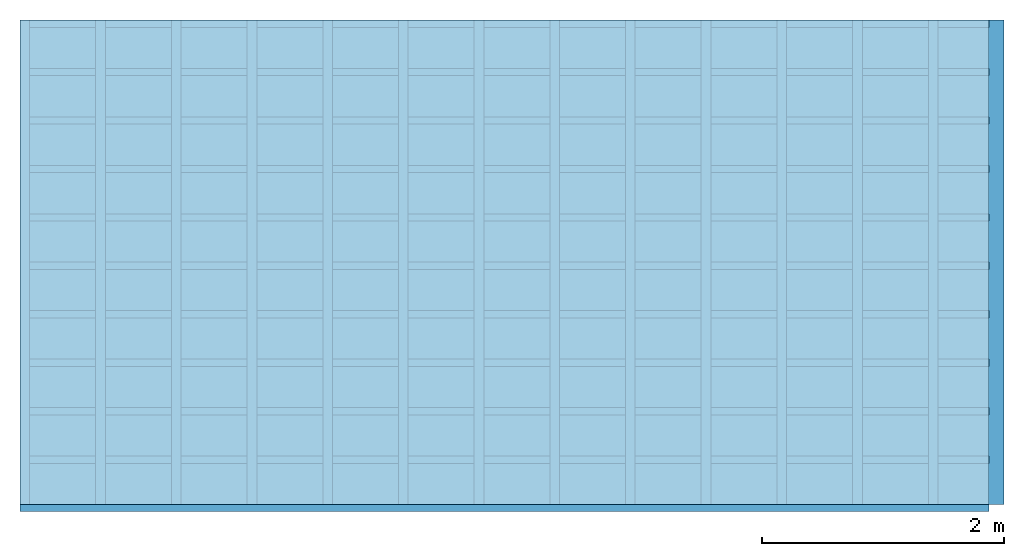
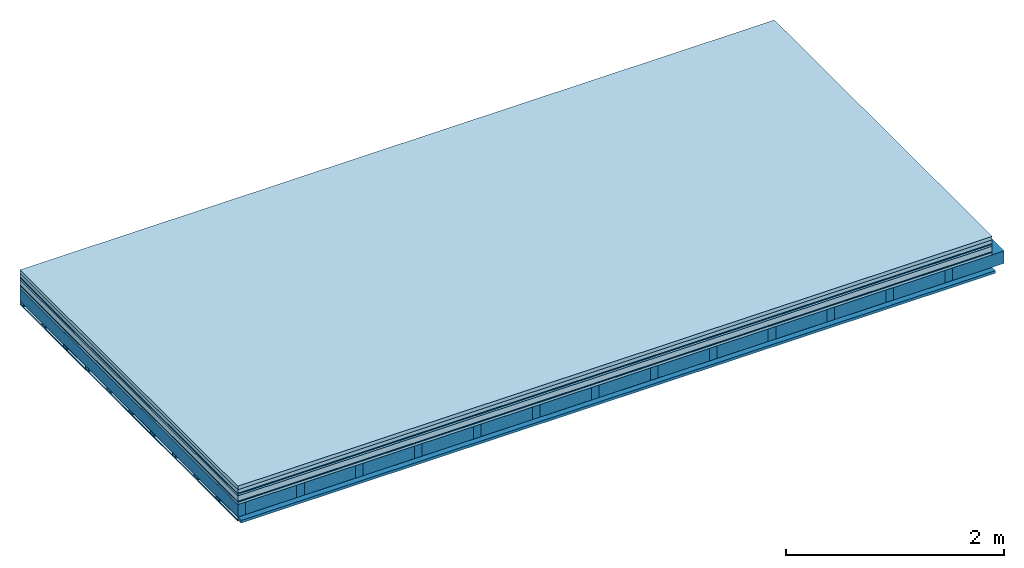
# One storey: 10 plates, 3 members, 1 element without a shape of its own.
"""IFC4 building model written with IfcOpenShell, lengths in metres."""

from ifc_helpers import new_model, si_unit, derived_unit, direction, frame, frame_2d, origin, origin_with_axes, place, context, project, spatial, rectangle, extrude, material, layer, layer_set, type_object, element, aggregate, save


model = new_model("IFC4")

# Units and contexts
plan_context = context("Plan", 3, precision=1e-05, world=origin(), true_north=direction((0.0, 1.0)))
model_context = context("Model", 3, precision=1e-05, world=origin(), true_north=direction((0.0, 1.0)))
ifc_project = project(units=[si_unit("LENGTHUNIT", "METRE"), derived_unit("SOUNDPRESSUREUNIT", [(si_unit("PRESSUREUNIT", "PASCAL", prefix="MICRO"), 0)]), si_unit("ENERGYUNIT", "JOULE", prefix="MEGA"), si_unit("MASSUNIT", "GRAM", prefix="KILO"), derived_unit("THERMALTRANSMITTANCEUNIT", [(si_unit("POWERUNIT", "WATT"), 1), (si_unit("AREAUNIT", "SQUARE_METRE"), -1), (si_unit("THERMODYNAMICTEMPERATUREUNIT", "KELVIN"), -1)]), derived_unit("AREADENSITYUNIT", [(si_unit("MASSUNIT", "GRAM", prefix="KILO"), 1), (si_unit("AREAUNIT", "SQUARE_METRE"), -1)]), derived_unit("USERDEFINED", [(si_unit("ENERGYUNIT", "JOULE", prefix="MEGA"), 1), (si_unit("AREAUNIT", "SQUARE_METRE"), -1)])], contexts=[plan_context, model_context])

# Site, building, storey
site = spatial("IfcSite", under=ifc_project)
building_placement = place(None, origin())
building = spatial("IfcBuilding", under=site, at=building_placement)
storey_placement = place(building_placement, origin())
storey = spatial("IfcBuildingStorey", under=building, at=storey_placement)

# Slab, members, plates
ifc_material_1 = material(Name="Garden plates", Category="02.007")
ifc_layer_1 = layer(ifc_material_1, 0.04, Name="Use and protection layer 3")
ifc_material_2 = material(Name="Gravel 8-16mm", Category="03.011")
ifc_layer_2 = layer(ifc_material_2, 0.04, Name="Use and protection layer 2")
ifc_material_3 = material(Name="Protective layer", Category="09.007")
ifc_layer_3 = layer(ifc_material_3, 0.01, Name="Use and protection layer 1")
ifc_material_4 = material(Name="Bituminous", Category="09.003")
ifc_layer_4 = layer(ifc_material_4, 0.02, Name="Seal")
ifc_material_5 = material(Name="Mineral wool", Category="10.008")
ifc_layer_5 = layer(ifc_material_5, 0.06, Name="Exterior insulation layer 1")
ifc_material_6 = material(Name="Vapor-permeable barrier", Category="09.006")
ifc_layer_6 = layer(ifc_material_6, 0.01, Name="layer / temporary roof")
ifc_material_7 = material(Name="3-layer panels", Category="07.001")
ifc_layer_7 = layer(ifc_material_7, 0.027, Name="above 2nd layer")
ifc_material_8 = material(Name="no composite action")
ifc_layer_8 = layer(ifc_material_8, 0.0, Name="Bond")
ifc_layer_9 = layer(None, 0.14, Name="Support")
ifc_material_9 = material(Name="of the art")
ifc_layer_10 = layer(ifc_material_9, 0.0, Name="Bond")
ifc_material_10 = material(Name="Vapor barrier polyethylene (PE)", Category="09.002")
ifc_layer_11 = layer(ifc_material_10, 0.001, Name="Vapor barrier")
ifc_layer_12 = layer(None, 0.03, Name="Battens / profiles")
ifc_material_11 = material(Name="Plasterboard type A", Category="03.008")
ifc_layer_13 = layer(ifc_material_11, 0.0125, Name="Covering below 1st layer")
ifc_material_12 = material(Category="04.001")
ifc_layer_14 = layer(ifc_material_12, 0.003, Name="Surface below")
ifc_layer_set = layer_set([ifc_layer_1, ifc_layer_2, ifc_layer_3, ifc_layer_4, ifc_layer_5, ifc_layer_6, ifc_layer_7, ifc_layer_8, ifc_layer_9, ifc_layer_10, ifc_layer_11, ifc_layer_12, ifc_layer_13, ifc_layer_14])
slab_type = type_object("IfcSlabType", Name="F0111", PredefinedType="NOTDEFINED", material=ifc_layer_set)
slab_placement = place(None, frame((0.0, 0.0, 0.0), z_axis=(0.0, 0.0, -1.0), x_axis=(1.0, 0.0, 0.0)))
slab = element("IfcSlab", 1, at=slab_placement, inside=storey, type_object=slab_type, material=ifc_layer_set, Name="Slab #1")
ifc_material_13 = material()
member_1_placement = place(slab_placement, origin())
member_1 = element("IfcMember", 2, at=member_1_placement, material=ifc_material_13, Name="Support", context=plan_context, shape_type="SweptSolid", body=[
    extrude(rectangle(XDim=0.08, YDim=0.14, at=frame_2d((0.04, 0.07), x_axis=(1.0, 0.0))), frame((0.0, 4.0, 0.207), z_axis=(0.0, -1.0, 0.0), x_axis=(1.0, 0.0, 0.0)), (0.0, 0.0, 1.0), 4.0),
    extrude(rectangle(XDim=0.08, YDim=0.14, at=frame_2d((0.04, 0.07), x_axis=(1.0, 0.0))), frame((0.625, 4.0, 0.207), z_axis=(0.0, -1.0, 0.0), x_axis=(1.0, 0.0, 0.0)), (0.0, 0.0, 1.0), 4.0),
    extrude(rectangle(XDim=0.08, YDim=0.14, at=frame_2d((0.04, 0.07), x_axis=(1.0, 0.0))), frame((1.25, 4.0, 0.207), z_axis=(0.0, -1.0, 0.0), x_axis=(1.0, 0.0, 0.0)), (0.0, 0.0, 1.0), 4.0),
    extrude(rectangle(XDim=0.08, YDim=0.14, at=frame_2d((0.04, 0.07), x_axis=(1.0, 0.0))), frame((1.875, 4.0, 0.207), z_axis=(0.0, -1.0, 0.0), x_axis=(1.0, 0.0, 0.0)), (0.0, 0.0, 1.0), 4.0),
    extrude(rectangle(XDim=0.08, YDim=0.14, at=frame_2d((0.04, 0.07), x_axis=(1.0, 0.0))), frame((2.5, 4.0, 0.207), z_axis=(0.0, -1.0, 0.0), x_axis=(1.0, 0.0, 0.0)), (0.0, 0.0, 1.0), 4.0),
    extrude(rectangle(XDim=0.08, YDim=0.14, at=frame_2d((0.04, 0.07), x_axis=(1.0, 0.0))), frame((3.125, 4.0, 0.207), z_axis=(0.0, -1.0, 0.0), x_axis=(1.0, 0.0, 0.0)), (0.0, 0.0, 1.0), 4.0),
    extrude(rectangle(XDim=0.08, YDim=0.14, at=frame_2d((0.04, 0.07), x_axis=(1.0, 0.0))), frame((3.75, 4.0, 0.207), z_axis=(0.0, -1.0, 0.0), x_axis=(1.0, 0.0, 0.0)), (0.0, 0.0, 1.0), 4.0),
    extrude(rectangle(XDim=0.08, YDim=0.14, at=frame_2d((0.04, 0.07), x_axis=(1.0, 0.0))), frame((4.375, 4.0, 0.207), z_axis=(0.0, -1.0, 0.0), x_axis=(1.0, 0.0, 0.0)), (0.0, 0.0, 1.0), 4.0),
    extrude(rectangle(XDim=0.08, YDim=0.14, at=frame_2d((0.04, 0.07), x_axis=(1.0, 0.0))), frame((5.0, 4.0, 0.207), z_axis=(0.0, -1.0, 0.0), x_axis=(1.0, 0.0, 0.0)), (0.0, 0.0, 1.0), 4.0),
    extrude(rectangle(XDim=0.08, YDim=0.14, at=frame_2d((0.04, 0.07), x_axis=(1.0, 0.0))), frame((5.625, 4.0, 0.207), z_axis=(0.0, -1.0, 0.0), x_axis=(1.0, 0.0, 0.0)), (0.0, 0.0, 1.0), 4.0),
    extrude(rectangle(XDim=0.08, YDim=0.14, at=frame_2d((0.04, 0.07), x_axis=(1.0, 0.0))), frame((6.25, 4.0, 0.207), z_axis=(0.0, -1.0, 0.0), x_axis=(1.0, 0.0, 0.0)), (0.0, 0.0, 1.0), 4.0),
    extrude(rectangle(XDim=0.08, YDim=0.14, at=frame_2d((0.04, 0.07), x_axis=(1.0, 0.0))), frame((6.875, 4.0, 0.207), z_axis=(0.0, -1.0, 0.0), x_axis=(1.0, 0.0, 0.0)), (0.0, 0.0, 1.0), 4.0),
    extrude(rectangle(XDim=0.08, YDim=0.14, at=frame_2d((0.04, 0.07), x_axis=(1.0, 0.0))), frame((7.5, 4.0, 0.207), z_axis=(0.0, -1.0, 0.0), x_axis=(1.0, 0.0, 0.0)), (0.0, 0.0, 1.0), 4.0),
])
ifc_material_14 = material()
member_2_placement = place(slab_placement, origin())
member_2 = element("IfcMember", 3, at=member_2_placement, material=ifc_material_14, Name="Cavity", context=plan_context, shape_type="SweptSolid", body=[
    extrude(rectangle(XDim=0.545, YDim=0.14, at=frame_2d((0.2725, 0.07), x_axis=(1.0, 0.0))), frame((0.08, 4.0, 0.207), z_axis=(0.0, -1.0, 0.0), x_axis=(1.0, 0.0, 0.0)), (0.0, 0.0, 1.0), 4.0),
    extrude(rectangle(XDim=0.545, YDim=0.14, at=frame_2d((0.2725, 0.07), x_axis=(1.0, 0.0))), frame((0.705, 4.0, 0.207), z_axis=(0.0, -1.0, 0.0), x_axis=(1.0, 0.0, 0.0)), (0.0, 0.0, 1.0), 4.0),
    extrude(rectangle(XDim=0.545, YDim=0.14, at=frame_2d((0.2725, 0.07), x_axis=(1.0, 0.0))), frame((1.33, 4.0, 0.207), z_axis=(0.0, -1.0, 0.0), x_axis=(1.0, 0.0, 0.0)), (0.0, 0.0, 1.0), 4.0),
    extrude(rectangle(XDim=0.545, YDim=0.14, at=frame_2d((0.2725, 0.07), x_axis=(1.0, 0.0))), frame((1.955, 4.0, 0.207), z_axis=(0.0, -1.0, 0.0), x_axis=(1.0, 0.0, 0.0)), (0.0, 0.0, 1.0), 4.0),
    extrude(rectangle(XDim=0.545, YDim=0.14, at=frame_2d((0.2725, 0.07), x_axis=(1.0, 0.0))), frame((2.58, 4.0, 0.207), z_axis=(0.0, -1.0, 0.0), x_axis=(1.0, 0.0, 0.0)), (0.0, 0.0, 1.0), 4.0),
    extrude(rectangle(XDim=0.545, YDim=0.14, at=frame_2d((0.2725, 0.07), x_axis=(1.0, 0.0))), frame((3.205, 4.0, 0.207), z_axis=(0.0, -1.0, 0.0), x_axis=(1.0, 0.0, 0.0)), (0.0, 0.0, 1.0), 4.0),
    extrude(rectangle(XDim=0.545, YDim=0.14, at=frame_2d((0.2725, 0.07), x_axis=(1.0, 0.0))), frame((3.83, 4.0, 0.207), z_axis=(0.0, -1.0, 0.0), x_axis=(1.0, 0.0, 0.0)), (0.0, 0.0, 1.0), 4.0),
    extrude(rectangle(XDim=0.545, YDim=0.14, at=frame_2d((0.2725, 0.07), x_axis=(1.0, 0.0))), frame((4.455, 4.0, 0.207), z_axis=(0.0, -1.0, 0.0), x_axis=(1.0, 0.0, 0.0)), (0.0, 0.0, 1.0), 4.0),
    extrude(rectangle(XDim=0.545, YDim=0.14, at=frame_2d((0.2725, 0.07), x_axis=(1.0, 0.0))), frame((5.08, 4.0, 0.207), z_axis=(0.0, -1.0, 0.0), x_axis=(1.0, 0.0, 0.0)), (0.0, 0.0, 1.0), 4.0),
    extrude(rectangle(XDim=0.545, YDim=0.14, at=frame_2d((0.2725, 0.07), x_axis=(1.0, 0.0))), frame((5.705, 4.0, 0.207), z_axis=(0.0, -1.0, 0.0), x_axis=(1.0, 0.0, 0.0)), (0.0, 0.0, 1.0), 4.0),
    extrude(rectangle(XDim=0.545, YDim=0.14, at=frame_2d((0.2725, 0.07), x_axis=(1.0, 0.0))), frame((6.33, 4.0, 0.207), z_axis=(0.0, -1.0, 0.0), x_axis=(1.0, 0.0, 0.0)), (0.0, 0.0, 1.0), 4.0),
    extrude(rectangle(XDim=0.545, YDim=0.14, at=frame_2d((0.2725, 0.07), x_axis=(1.0, 0.0))), frame((6.955, 4.0, 0.207), z_axis=(0.0, -1.0, 0.0), x_axis=(1.0, 0.0, 0.0)), (0.0, 0.0, 1.0), 4.0),
    extrude(rectangle(XDim=0.545, YDim=0.14, at=frame_2d((0.2725, 0.07), x_axis=(1.0, 0.0))), frame((7.58, 4.0, 0.207), z_axis=(0.0, -1.0, 0.0), x_axis=(1.0, 0.0, 0.0)), (0.0, 0.0, 1.0), 4.0),
])
ifc_material_15 = material()
member_3_placement = place(slab_placement, origin())
member_3 = element("IfcMember", 4, at=member_3_placement, material=ifc_material_15, Name="Battens / profiles", context=plan_context, shape_type="SweptSolid", body=[
    extrude(rectangle(XDim=0.06, YDim=0.03, at=frame_2d((0.03, 0.015), x_axis=(1.0, 0.0))), frame((0.0, 0.0, 0.348), z_axis=(1.0, 0.0, 0.0), x_axis=(0.0, 1.0, 0.0)), (0.0, 0.0, 1.0), 8.0),
    extrude(rectangle(XDim=0.06, YDim=0.03, at=frame_2d((0.03, 0.015), x_axis=(1.0, 0.0))), frame((0.0, 0.4, 0.348), z_axis=(1.0, 0.0, 0.0), x_axis=(0.0, 1.0, 0.0)), (0.0, 0.0, 1.0), 8.0),
    extrude(rectangle(XDim=0.06, YDim=0.03, at=frame_2d((0.03, 0.015), x_axis=(1.0, 0.0))), frame((0.0, 0.8, 0.348), z_axis=(1.0, 0.0, 0.0), x_axis=(0.0, 1.0, 0.0)), (0.0, 0.0, 1.0), 8.0),
    extrude(rectangle(XDim=0.06, YDim=0.03, at=frame_2d((0.03, 0.015), x_axis=(1.0, 0.0))), frame((0.0, 1.2, 0.348), z_axis=(1.0, 0.0, 0.0), x_axis=(0.0, 1.0, 0.0)), (0.0, 0.0, 1.0), 8.0),
    extrude(rectangle(XDim=0.06, YDim=0.03, at=frame_2d((0.03, 0.015), x_axis=(1.0, 0.0))), frame((0.0, 1.6, 0.348), z_axis=(1.0, 0.0, 0.0), x_axis=(0.0, 1.0, 0.0)), (0.0, 0.0, 1.0), 8.0),
    extrude(rectangle(XDim=0.06, YDim=0.03, at=frame_2d((0.03, 0.015), x_axis=(1.0, 0.0))), frame((0.0, 2.0, 0.348), z_axis=(1.0, 0.0, 0.0), x_axis=(0.0, 1.0, 0.0)), (0.0, 0.0, 1.0), 8.0),
    extrude(rectangle(XDim=0.06, YDim=0.03, at=frame_2d((0.03, 0.015), x_axis=(1.0, 0.0))), frame((0.0, 2.4, 0.348), z_axis=(1.0, 0.0, 0.0), x_axis=(0.0, 1.0, 0.0)), (0.0, 0.0, 1.0), 8.0),
    extrude(rectangle(XDim=0.06, YDim=0.03, at=frame_2d((0.03, 0.015), x_axis=(1.0, 0.0))), frame((0.0, 2.8, 0.348), z_axis=(1.0, 0.0, 0.0), x_axis=(0.0, 1.0, 0.0)), (0.0, 0.0, 1.0), 8.0),
    extrude(rectangle(XDim=0.06, YDim=0.03, at=frame_2d((0.03, 0.015), x_axis=(1.0, 0.0))), frame((0.0, 3.2, 0.348), z_axis=(1.0, 0.0, 0.0), x_axis=(0.0, 1.0, 0.0)), (0.0, 0.0, 1.0), 8.0),
    extrude(rectangle(XDim=0.06, YDim=0.03, at=frame_2d((0.03, 0.015), x_axis=(1.0, 0.0))), frame((0.0, 3.6, 0.348), z_axis=(1.0, 0.0, 0.0), x_axis=(0.0, 1.0, 0.0)), (0.0, 0.0, 1.0), 8.0),
    extrude(rectangle(XDim=0.06, YDim=0.03, at=frame_2d((0.03, 0.015), x_axis=(1.0, 0.0))), frame((0.0, 4.0, 0.348), z_axis=(1.0, 0.0, 0.0), x_axis=(0.0, 1.0, 0.0)), (0.0, 0.0, 1.0), 8.0),
])
plate_1_placement = place(slab_placement, origin())
plate_1 = element("IfcPlate", 5, at=plate_1_placement, material=ifc_material_1, Name="Use and protection layer 3", context=plan_context, shape_type="SweptSolid", body=[
    extrude(rectangle(XDim=8.0, YDim=4.0, at=frame_2d((4.0, 2.0), x_axis=(1.0, 0.0))), origin_with_axes(), (0.0, 0.0, 1.0), 0.04),
])
plate_2_placement = place(slab_placement, origin())
plate_2 = element("IfcPlate", 6, at=plate_2_placement, material=ifc_material_2, Name="Use and protection layer 2", context=plan_context, shape_type="SweptSolid", body=[
    extrude(rectangle(XDim=8.0, YDim=4.0, at=frame_2d((4.0, 2.0), x_axis=(1.0, 0.0))), frame((0.0, 0.0, 0.04), z_axis=(0.0, 0.0, 1.0), x_axis=(1.0, 0.0, 0.0)), (0.0, 0.0, 1.0), 0.04),
])
plate_3_placement = place(slab_placement, origin())
plate_3 = element("IfcPlate", 7, at=plate_3_placement, material=ifc_material_3, Name="Use and protection layer 1", context=plan_context, shape_type="SweptSolid", body=[
    extrude(rectangle(XDim=8.0, YDim=4.0, at=frame_2d((4.0, 2.0), x_axis=(1.0, 0.0))), frame((0.0, 0.0, 0.08), z_axis=(0.0, 0.0, 1.0), x_axis=(1.0, 0.0, 0.0)), (0.0, 0.0, 1.0), 0.01),
])
plate_4_placement = place(slab_placement, origin())
plate_4 = element("IfcPlate", 8, at=plate_4_placement, material=ifc_material_4, Name="Seal", context=plan_context, shape_type="SweptSolid", body=[
    extrude(rectangle(XDim=8.0, YDim=4.0, at=frame_2d((4.0, 2.0), x_axis=(1.0, 0.0))), frame((0.0, 0.0, 0.09), z_axis=(0.0, 0.0, 1.0), x_axis=(1.0, 0.0, 0.0)), (0.0, 0.0, 1.0), 0.02),
])
plate_5_placement = place(slab_placement, origin())
plate_5 = element("IfcPlate", 9, at=plate_5_placement, material=ifc_material_5, Name="Exterior insulation layer 1", context=plan_context, shape_type="SweptSolid", body=[
    extrude(rectangle(XDim=8.0, YDim=4.0, at=frame_2d((4.0, 2.0), x_axis=(1.0, 0.0))), frame((0.0, 0.0, 0.11), z_axis=(0.0, 0.0, 1.0), x_axis=(1.0, 0.0, 0.0)), (0.0, 0.0, 1.0), 0.06),
])
plate_6_placement = place(slab_placement, origin())
plate_6 = element("IfcPlate", 10, at=plate_6_placement, material=ifc_material_6, Name="layer / temporary roof", context=plan_context, shape_type="SweptSolid", body=[
    extrude(rectangle(XDim=8.0, YDim=4.0, at=frame_2d((4.0, 2.0), x_axis=(1.0, 0.0))), frame((0.0, 0.0, 0.17), z_axis=(0.0, 0.0, 1.0), x_axis=(1.0, 0.0, 0.0)), (0.0, 0.0, 1.0), 0.01),
])
plate_7_placement = place(slab_placement, origin())
plate_7 = element("IfcPlate", 11, at=plate_7_placement, material=ifc_material_7, Name="above 2nd layer", context=plan_context, shape_type="SweptSolid", body=[
    extrude(rectangle(XDim=8.0, YDim=4.0, at=frame_2d((4.0, 2.0), x_axis=(1.0, 0.0))), frame((0.0, 0.0, 0.18), z_axis=(0.0, 0.0, 1.0), x_axis=(1.0, 0.0, 0.0)), (0.0, 0.0, 1.0), 0.027),
])
plate_8_placement = place(slab_placement, origin())
plate_8 = element("IfcPlate", 12, at=plate_8_placement, material=ifc_material_10, Name="Vapor barrier", context=plan_context, shape_type="SweptSolid", body=[
    extrude(rectangle(XDim=8.0, YDim=4.0, at=frame_2d((4.0, 2.0), x_axis=(1.0, 0.0))), frame((0.0, 0.0, 0.347), z_axis=(0.0, 0.0, 1.0), x_axis=(1.0, 0.0, 0.0)), (0.0, 0.0, 1.0), 0.001),
])
plate_9_placement = place(slab_placement, origin())
plate_9 = element("IfcPlate", 13, at=plate_9_placement, material=ifc_material_11, Name="Covering below 1st layer", context=plan_context, shape_type="SweptSolid", body=[
    extrude(rectangle(XDim=8.0, YDim=4.0, at=frame_2d((4.0, 2.0), x_axis=(1.0, 0.0))), frame((0.0, 0.0, 0.378), z_axis=(0.0, 0.0, 1.0), x_axis=(1.0, 0.0, 0.0)), (0.0, 0.0, 1.0), 0.0125),
])
plate_10_placement = place(slab_placement, origin())
plate_10 = element("IfcPlate", 14, at=plate_10_placement, material=ifc_material_12, Name="Surface below", context=plan_context, shape_type="SweptSolid", body=[
    extrude(rectangle(XDim=8.0, YDim=4.0, at=frame_2d((4.0, 2.0), x_axis=(1.0, 0.0))), frame((0.0, 0.0, 0.3905), z_axis=(0.0, 0.0, 1.0), x_axis=(1.0, 0.0, 0.0)), (0.0, 0.0, 1.0), 0.003),
])
aggregate(slab, [plate_1, plate_2, plate_3, plate_4, plate_5, plate_6, plate_7, member_1, member_2, plate_8, member_3, plate_9, plate_10])

save(model, "model.ifc")
